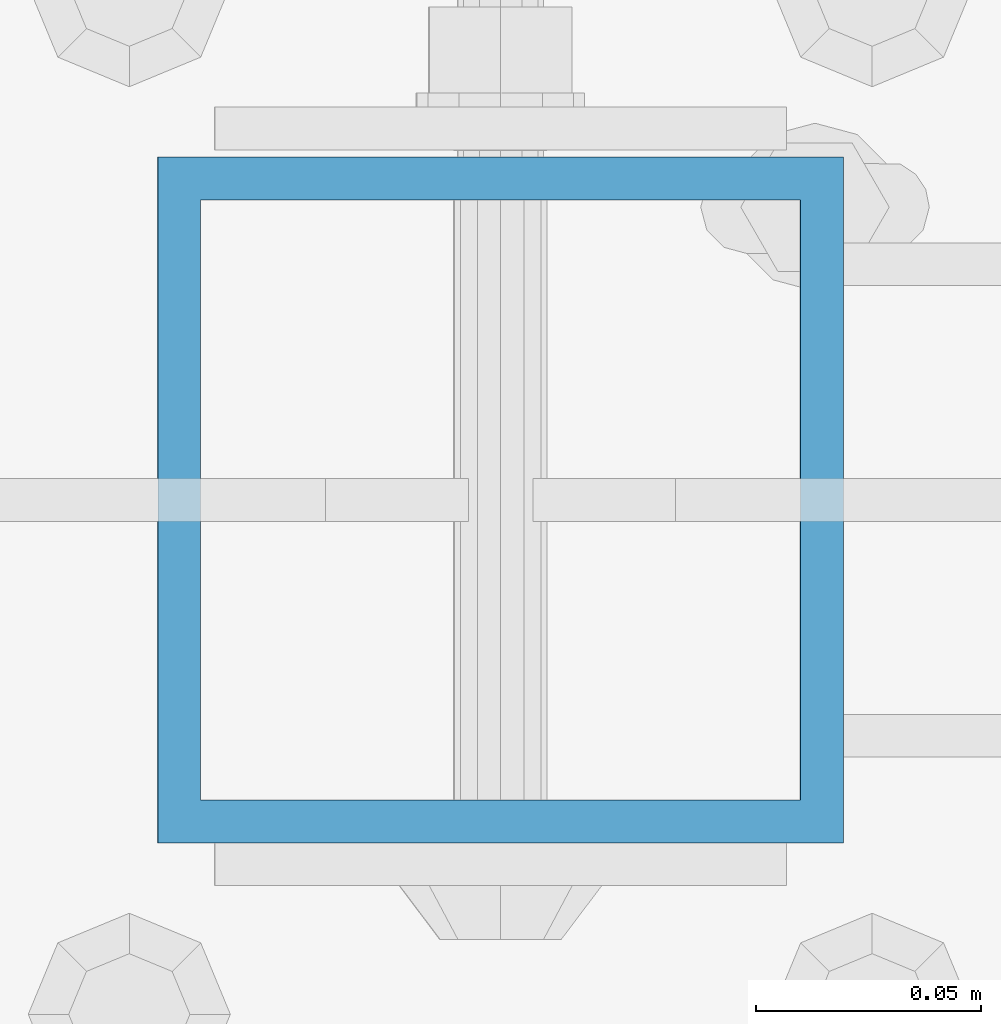
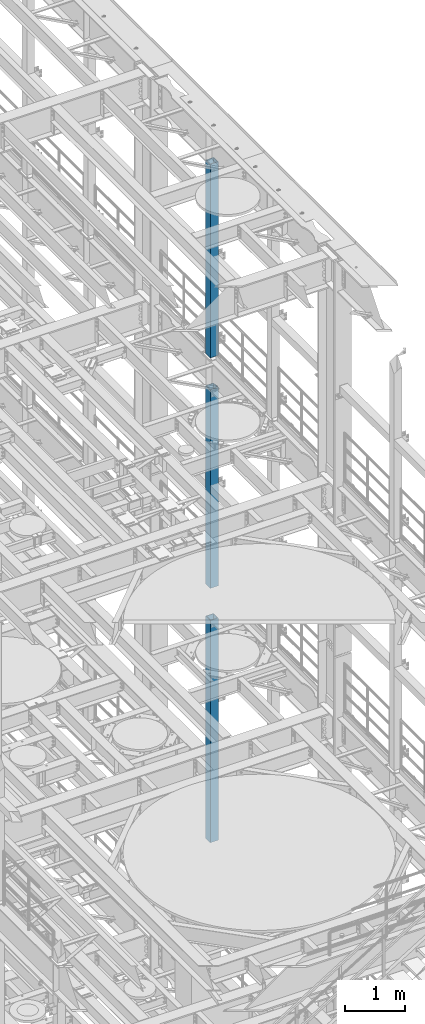
# One storey, part 725 of 1876: 3 columns, 3 elements without a shape of their own.
"""IFC2X3 building model written with IfcOpenShell, lengths in millimetres."""

from ifc_helpers import new_model, si_unit, frame, origin_with_axes, place, context, subcontext, project, spatial, faceted_brep, material, type_object, element, aggregate, save


model = new_model("IFC2X3")

# Units and contexts
model_context = context("Model", 3, precision=1e-05, world=origin_with_axes())
body_context = subcontext(model_context, "Body", "Model", "MODEL_VIEW")
ifc_project = project(units=[si_unit("LENGTHUNIT", "METRE", prefix="MILLI"), si_unit("AREAUNIT", "SQUARE_METRE"), si_unit("VOLUMEUNIT", "CUBIC_METRE"), si_unit("MASSUNIT", "GRAM", prefix="KILO"), si_unit("TIMEUNIT", "SECOND"), si_unit("PLANEANGLEUNIT", "RADIAN"), si_unit("SOLIDANGLEUNIT", "STERADIAN"), si_unit("THERMODYNAMICTEMPERATUREUNIT", "DEGREE_CELSIUS"), si_unit("LUMINOUSINTENSITYUNIT", "LUMEN")], contexts=[model_context])

# Site, building, storey
site_placement = place(None, origin_with_axes())
site = spatial("IfcSite", under=ifc_project, at=site_placement, CompositionType="ELEMENT")
building_placement = place(site_placement, origin_with_axes())
building = spatial("IfcBuilding", under=site, at=building_placement, Name="Undefined", CompositionType="ELEMENT")
storey_placement = place(building_placement, origin_with_axes())
storey = spatial("IfcBuildingStorey", under=building, at=storey_placement, Name="Undefined", CompositionType="ELEMENT", Elevation=0.0)

# Assembly, column
assembly_1_placement = place(storey_placement, origin_with_axes())
assembly_1 = element("IfcElementAssembly", 1, at=assembly_1_placement, inside=storey, Name="BEAM", AssemblyPlace="NOTDEFINED", PredefinedType="RIGID_FRAME")
ifc_material = material()
column_type = type_object("IfcColumnType", Name="HSS6X6X3/8", PredefinedType="NOTDEFINED")
column_1_placement = place(assembly_1_placement, frame((7620.0, 5588.0, 17983.2), z_axis=(-1.0, 0.0, 0.0), x_axis=(0.0, 0.0, 1.0)))
column_1 = element("IfcColumn", 2, at=column_1_placement, type_object=column_type, material=ifc_material, Name="COLUMN", ObjectType="HSS6X6X3/8", context=body_context, shape_type="Brep", body=[
    faceted_brep([(12.7000000000016, 66.6750000000002, -66.6750000000002), (12.7000000000016, -66.6750000000002, -66.6750000000002), (3937.0, -66.6750000000002, -66.675), (3937.0, 66.6750000000002, -66.675), (12.7000000000016, -66.6750000000002, 66.6750000000002), (3937.0, -66.6750000000002, 66.675), (12.7000000000016, 66.6750000000002, 66.6750000000002), (3937.0, 66.6750000000002, 66.675), (12.7000000000016, 76.1999999999998, -76.1999999999998), (12.7000000000016, 76.1999999999998, 76.1999999999998), (3937.0, 76.1999999999998, 76.2), (3937.0, 76.1999999999998, -76.2), (12.7000000000016, -76.1999999999998, 76.1999999999998), (3937.0, -76.1999999999998, 76.2), (12.7000000000016, -76.1999999999998, -76.1999999999998), (3937.0, -76.1999999999998, -76.2)], [[[0, 1, 2, 3]], [[1, 4, 5, 2]], [[4, 6, 7, 5]], [[6, 0, 3, 7]], [[8, 9, 10, 11]], [[9, 12, 13, 10]], [[12, 14, 15, 13]], [[14, 8, 11, 15]], [[13, 15, 11, 10], [5, 7, 3, 2]], [[14, 12, 9, 8], [6, 4, 1, 0]]]),
])
aggregate(assembly_1, [column_1])

assembly_2_placement = place(storey_placement, origin_with_axes())
assembly_2 = element("IfcElementAssembly", 3, at=assembly_2_placement, inside=storey, Name="BEAM", AssemblyPlace="NOTDEFINED", PredefinedType="RIGID_FRAME")
column_2_placement = place(assembly_2_placement, frame((7620.0, 5588.0, 13309.6), z_axis=(-1.0, 0.0, 0.0), x_axis=(0.0, 0.0, 1.0)))
column_2 = element("IfcColumn", 4, at=column_2_placement, type_object=column_type, material=ifc_material, Name="COLUMN", ObjectType="HSS6X6X3/8", context=body_context, shape_type="Brep", body=[
    faceted_brep([(12.7000000000016, 66.6750000000002, -66.6750000000002), (12.7000000000016, -66.6750000000002, -66.6750000000002), (4038.6, -66.6750000000002, -66.675), (4038.6, 66.6750000000002, -66.675), (12.7000000000016, -66.6750000000002, 66.6750000000002), (4038.6, -66.6750000000002, 66.675), (12.7000000000016, 66.6750000000002, 66.6750000000002), (4038.6, 66.6750000000002, 66.675), (12.7000000000016, 76.1999999999998, -76.1999999999998), (12.7000000000016, 76.1999999999998, 76.1999999999998), (4038.6, 76.1999999999998, 76.2), (4038.6, 76.1999999999998, -76.2), (12.7000000000016, -76.1999999999998, 76.1999999999998), (4038.6, -76.1999999999998, 76.2), (12.7000000000016, -76.1999999999998, -76.1999999999998), (4038.6, -76.1999999999998, -76.2)], [[[0, 1, 2, 3]], [[1, 4, 5, 2]], [[4, 6, 7, 5]], [[6, 0, 3, 7]], [[8, 9, 10, 11]], [[9, 12, 13, 10]], [[12, 14, 15, 13]], [[14, 8, 11, 15]], [[13, 15, 11, 10], [5, 7, 3, 2]], [[14, 12, 9, 8], [6, 4, 1, 0]]]),
])
aggregate(assembly_2, [column_2])

assembly_3_placement = place(storey_placement, origin_with_axes())
assembly_3 = element("IfcElementAssembly", 5, at=assembly_3_placement, inside=storey, Name="BEAM", AssemblyPlace="NOTDEFINED", PredefinedType="RIGID_FRAME")
column_3_placement = place(assembly_3_placement, frame((7620.0, 5588.0, 8153.4), z_axis=(-0.999999999563517, 0.0, -2.95459999870218e-05), x_axis=(-2.95459999861759e-05, 0.0, 0.999999999563517)))
column_3 = element("IfcColumn", 6, at=column_3_placement, type_object=column_type, material=ifc_material, Name="COLUMN", ObjectType="HSS6X6X3/8", context=body_context, shape_type="Brep", body=[
    faceted_brep([(12.698030025992, 66.6750000000002, -66.675), (12.698030025992, -66.6750000000002, -66.675), (4521.2007045434, -66.6750000000002, -66.675), (4521.2007045434, 66.6750000000002, -66.675), (12.7019699850925, -66.6750000000002, 66.675), (4521.20070454334, -66.6750000000002, 66.675), (12.7019699850925, 66.6750000000002, 66.675), (4521.20070454334, 66.6750000000002, 66.675), (12.6977486003425, 76.1999999999998, -76.2), (12.7022514107421, 76.1999999999998, 76.2), (4521.20070454334, 76.1999999999998, 76.2), (4521.2007045434, 76.1999999999998, -76.2), (12.7022514107421, -76.1999999999998, 76.2), (4521.20070454334, -76.1999999999998, 76.2), (12.6977486003425, -76.1999999999998, -76.2), (4521.2007045434, -76.1999999999998, -76.2)], [[[0, 1, 2, 3]], [[1, 4, 5, 2]], [[4, 6, 7, 5]], [[6, 0, 3, 7]], [[8, 9, 10, 11]], [[9, 12, 13, 10]], [[12, 14, 15, 13]], [[14, 8, 11, 15]], [[13, 15, 11, 10], [5, 7, 3, 2]], [[14, 12, 9, 8], [6, 4, 1, 0]]]),
])
aggregate(assembly_3, [column_3])

save(model, "model.ifc")
